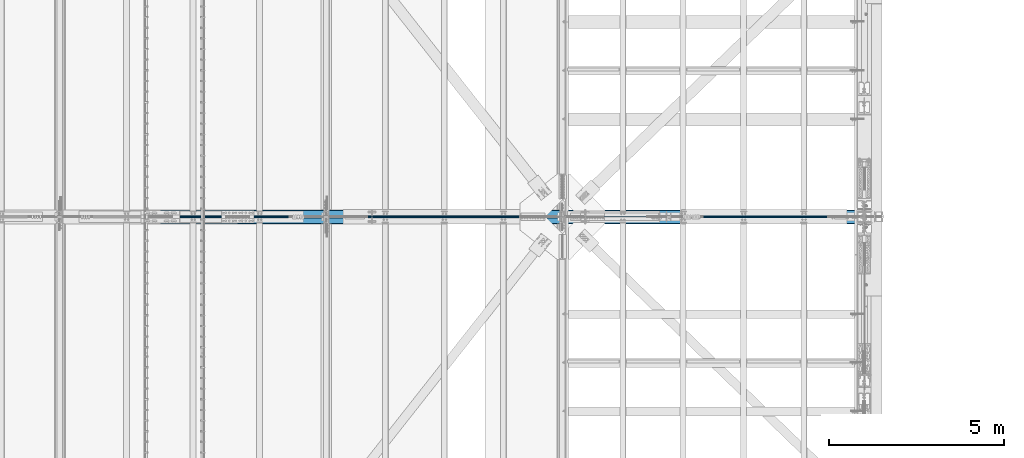
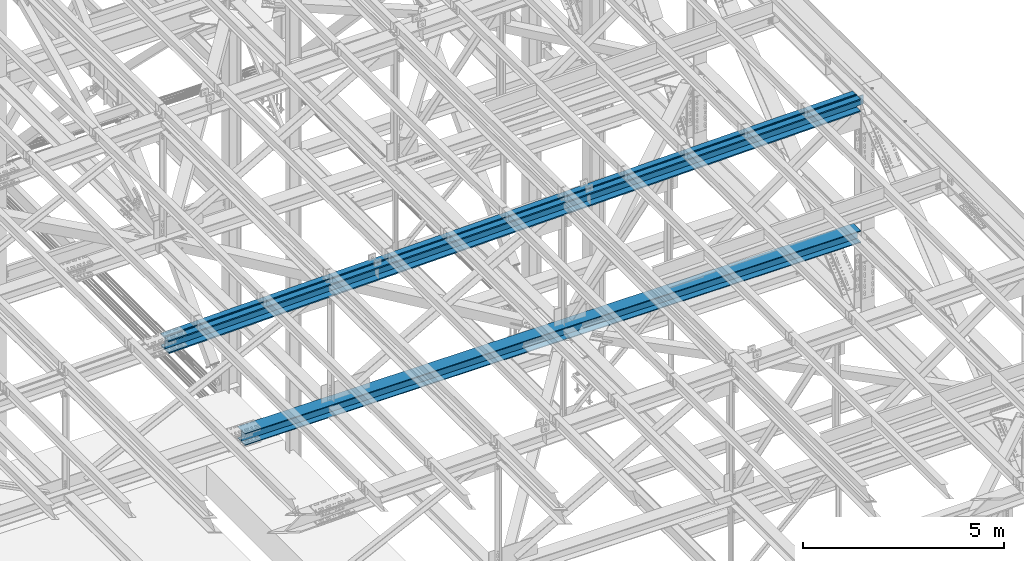
# One storey, part 1906 of 3843: 3 beams, 3 elements without a shape of their own.
"""IFC2X3 building model written with IfcOpenShell, lengths in millimetres."""

from ifc_helpers import new_model, si_unit, frame, origin_with_axes, place, context, subcontext, project, spatial, faceted_brep, material, type_object, element, aggregate, save


model = new_model("IFC2X3")

# Units and contexts
model_context = context("Model", 3, precision=1e-05, world=origin_with_axes())
body_context = subcontext(model_context, "Body", "Model", "MODEL_VIEW")
ifc_project = project(units=[si_unit("LENGTHUNIT", "METRE", prefix="MILLI"), si_unit("AREAUNIT", "SQUARE_METRE"), si_unit("VOLUMEUNIT", "CUBIC_METRE"), si_unit("MASSUNIT", "GRAM", prefix="KILO"), si_unit("TIMEUNIT", "SECOND"), si_unit("PLANEANGLEUNIT", "RADIAN"), si_unit("SOLIDANGLEUNIT", "STERADIAN"), si_unit("THERMODYNAMICTEMPERATUREUNIT", "DEGREE_CELSIUS"), si_unit("LUMINOUSINTENSITYUNIT", "LUMEN")], contexts=[model_context])

# Site, building, storey
site_placement = place(None, origin_with_axes())
site = spatial("IfcSite", under=ifc_project, at=site_placement, CompositionType="ELEMENT")
building_placement = place(site_placement, origin_with_axes())
building = spatial("IfcBuilding", under=site, at=building_placement, Name="Undefined", CompositionType="ELEMENT")
storey_placement = place(building_placement, origin_with_axes())
storey = spatial("IfcBuildingStorey", under=building, at=storey_placement, Name="Undefined", CompositionType="ELEMENT", Elevation=0.0)

# Assembly, beam
assembly_1_placement = place(storey_placement, origin_with_axes())
assembly_1 = element("IfcElementAssembly", 1, at=assembly_1_placement, inside=storey, Name="dummy", AssemblyPlace="NOTDEFINED", PredefinedType="RIGID_FRAME")
ifc_material = material(Name="STEEL/A992")
beam_type_1 = type_object("IfcBeamType", PredefinedType="NOTDEFINED")
beam_1_placement = place(assembly_1_placement, frame((65512.9690554867, 75628.5, 46111.090973795), z_axis=(-0.019790410992835, 0.0, 0.999804150637881), x_axis=(0.999804150637881, 0.0, 0.019790410992832)))
beam_1 = element("IfcBeam", 2, at=beam_1_placement, type_object=beam_type_1, material=ifc_material, Name="dummy", context=body_context, shape_type="Brep", body=[
    faceted_brep([(0.0, -24.6059999999998, 0.0), (0.0, -21.3094210855197, -12.3029999999999), (19921.5396437136, -21.3094210855197, -12.3029999482751), (19921.5396437135, -24.6059999999998, 5.17538865096867e-08), (0.0, -12.3029999999999, -21.3094210855197), (19921.5396437136, -12.3029999999999, -21.309421033824), (0.0, 0.0, -24.6059999999998), (19921.5396437136, 0.0, -24.6059999483186), (0.0, 12.3029999999999, -21.3094210855197), (19921.5396437136, 12.3029999999999, -21.309421033824), (0.0, 21.3094210855197, -12.3029999999999), (19921.5396437136, 21.3094210855197, -12.3029999482751), (0.0, 24.6059999999998, 0.0), (19921.5396437135, 24.6059999999998, 5.17538865096867e-08), (0.0, 21.3094210855197, 12.3029999999999), (19921.5396437135, 21.3094210855197, 12.3030000517901), (0.0, 12.3029999999999, 21.3094210855197), (19921.5396437135, 12.3029999999999, 21.3094211373318), (0.0, 0.0, 24.6059999999998), (19921.5396437135, 0.0, 24.6060000518191), (0.0, -12.3029999999999, 21.3094210855197), (19921.5396437135, -12.3029999999999, 21.3094211373318), (0.0, -21.3094210855197, 12.3029999999999), (19921.5396437135, -21.3094210855197, 12.3030000517901)], [[[0, 1, 2, 3]], [[1, 4, 5, 2]], [[4, 6, 7, 5]], [[6, 8, 9, 7]], [[8, 10, 11, 9]], [[10, 12, 13, 11]], [[12, 14, 15, 13]], [[14, 16, 17, 15]], [[16, 18, 19, 17]], [[18, 20, 21, 19]], [[20, 22, 23, 21]], [[22, 0, 3, 23]], [[5, 7, 9, 11, 13, 15, 17, 19, 21, 23, 3, 2]], [[22, 20, 18, 16, 14, 12, 10, 8, 6, 4, 1, 0]]]),
])
aggregate(assembly_1, [beam_1])

assembly_2_placement = place(storey_placement, origin_with_axes())
assembly_2 = element("IfcElementAssembly", 3, at=assembly_2_placement, inside=storey, Name="BEAM", AssemblyPlace="NOTDEFINED", PredefinedType="RIGID_FRAME")
beam_type_2 = type_object("IfcBeamType", Name="W14X193", PredefinedType="NOTDEFINED")
beam_2_placement = place(assembly_2_placement, frame((65510.8293646569, 75628.5, 45914.1524515103), z_axis=(-0.0197786729982909, 0.0, 0.999804382914191), x_axis=(0.999804380738174, 0.0, 0.0197787829948203)))
beam_2 = element("IfcBeam", 4, at=beam_2_placement, type_object=beam_type_2, material=ifc_material, Name="BEAM", ObjectType="W14X193", context=body_context, shape_type="Brep", body=[
    faceted_brep([(19920.5612871761, -11.1125000000029, -159.992412711617), (19920.5612871761, -200.025000000001, -159.992412711617), (19920.499121162, -200.025000000001, -196.504859770212), (19920.499121162, 200.025000000001, -196.504859770212), (19920.5612871761, 200.025000000001, -159.992412711617), (19920.5612871761, 11.1125000000029, -159.992412711617), (19920.5748656065, 11.1125000000029, -152.017287854047), (19920.5748656065, -11.1125000000029, -152.017287854047), (19921.5498688769, 11.1125000000029, -147.158861330223), (19921.5498688769, -11.1125000000029, -147.158861330223), (19924.3098937806, 11.1125000000029, -143.043378102717), (19924.3098937806, -11.1125000000029, -143.043378102717), (19928.4347515457, 11.1125000000029, -140.297383185971), (19928.4347515457, -11.1125000000029, -140.297383185971), (19933.2964699694, 11.1125000000029, -139.338929413556), (19933.2964699694, -11.1125000000029, -139.338929413556), (20111.3615741998, -11.1125000000029, -139.642102676553), (20111.3615741998, 11.1125000000029, -139.642102676553), (16116.5786885021, 200.025000000001, 202.348008926172), (16116.5786885021, -200.025000000001, 202.348008926172), (18131.1922933243, -200.025000000001, 199.942504537845), (18131.1922933243, 200.025000000001, 199.942504537845), (14101.9643802748, 200.025000000001, 204.066226545852), (14101.9643802748, -200.025000000001, 204.066226545852), (12087.3496031107, 200.025000000001, 205.097157195742), (12087.3496031107, -200.025000000001, 205.097157195742), (10072.7345914782, 200.025000000001, 205.440800756616), (10072.7345914782, -200.025000000001, 205.440800756616), (8058.1195798456, 200.025000000001, 205.097157188429), (8058.1195798456, -200.025000000001, 205.097157188429), (6043.50480268151, 200.025000000001, 204.066226531235), (6043.50480268151, -200.025000000001, 204.066226531235), (4028.89049445419, 200.025000000001, 202.348008904228), (4028.89049445419, -200.025000000001, 202.348008904228), (2014.27688963198, 200.025000000001, 199.942504508603), (2014.27688963198, -200.025000000001, 199.942504508603), (6.0142170227482, 200.025000000001, 196.859462000226), (6.0142170227482, -200.025000000001, 196.859462000226), (18131.1424682946, 11.1125000000029, 163.430038533632), (18131.1424682946, 200.025000000001, 163.430038533632), (19927.4572595197, 200.025000000001, 160.67237395011), (19927.4572595197, 11.1125000000029, 160.67237395011), (16116.5413197247, 11.1125000000029, 165.835528048839), (16116.5413197247, 200.025000000001, 165.835528048839), (14101.9394677542, 11.1125000000029, 167.553735044879), (14101.9394677542, 200.025000000001, 167.553735044879), (12087.3371468497, 11.1125000000029, 168.584659320572), (12087.3371468497, 200.025000000001, 168.584659320572), (10072.7345914782, 11.1125000000029, 168.928300756721), (10072.7345914782, 200.025000000001, 168.928300756721), (8058.13203610678, 11.1125000000029, 168.584659313266), (8058.13203610678, 200.025000000001, 168.584659313266), (6043.52971520228, 11.1125000000029, 167.553735030247), (6043.52971520228, 200.025000000001, 167.553735030247), (4028.92786323171, 11.1125000000029, 165.835528026902), (4028.92786323171, 200.025000000001, 165.835528026902), (2014.3267146619, 11.1125000000029, 163.430038504383), (2014.3267146619, 200.025000000001, 163.430038504383), (6.07649798043713, 11.1125000000029, 160.347015118088), (6.07649798043713, 200.025000000001, 160.347015118088), (16116.2131243754, 200.025000000001, -154.839304004214), (16116.2131243754, 11.1125000000029, -154.839304004214), (18130.7048745547, 11.1125000000029, -157.244662894722), (18130.7048745547, 200.025000000001, -157.244662894722), (14101.7206708336, 200.025000000001, -153.121190311555), (14101.7206708336, 11.1125000000029, -153.121190311555), (12087.2277483833, 200.025000000001, -152.090322017881), (12087.2277483833, 11.1125000000029, -152.090322017881), (10072.7345914788, 200.025000000001, -151.746699242423), (10072.7345914788, 11.1125000000029, -151.746699242423), (8058.2414345743, 200.025000000001, -152.0903220252), (8058.2414345743, 11.1125000000029, -152.0903220252), (6043.74851212402, 200.025000000001, -153.121190326179), (6043.74851212402, 11.1125000000029, -153.121190326179), (4029.25605858218, 200.025000000001, -154.839304026151), (4029.25605858218, 11.1125000000029, -154.839304026151), (2014.76430840291, 200.025000000001, -157.244662923971), (2014.76430840291, 11.1125000000029, -157.244662923971), (6.62348726096388, 200.025000000001, -160.327518368547), (6.62348726096388, 11.1125000000029, -160.327518368547), (16116.175755598, -200.025000000001, -191.351784881546), (16116.175755598, 200.025000000001, -191.351784881546), (18130.6550495249, 200.025000000001, -193.757128898935), (18130.6550495249, -200.025000000001, -193.757128898935), (14101.6957583129, -200.025000000001, -189.633681812535), (14101.6957583129, 200.025000000001, -189.633681812535), (12087.2152921223, -200.025000000001, -188.602819893051), (12087.2152921223, 200.025000000001, -188.602819893051), (10072.7345914789, -200.025000000001, -188.259199242319), (10072.7345914789, 200.025000000001, -188.259199242319), (8058.25389083543, -200.025000000001, -188.60281990037), (8058.25389083543, 200.025000000001, -188.60281990037), (6043.77342464479, -200.025000000001, -189.633681827167), (6043.77342464479, 200.025000000001, -189.633681827167), (4029.29342735971, -200.025000000001, -191.351784903483), (4029.29342735971, 200.025000000001, -191.351784903483), (2014.81413343282, -200.025000000001, -193.757128928191), (2014.81413343282, 200.025000000001, -193.757128928191), (6.68576821865281, -200.025000000001, -196.839965250685), (6.68576821865281, 200.025000000001, -196.839965250685), (16116.2131243754, -11.1125000000029, -154.839304004214), (16116.2131243754, -200.025000000001, -154.839304004214), (18130.7048745547, -200.025000000001, -157.244662894722), (18130.7048745547, -11.1125000000029, -157.244662894722), (14101.7206708336, -11.1125000000029, -153.121190311555), (14101.7206708336, -200.025000000001, -153.121190311555), (12087.2277483833, -11.1125000000029, -152.090322017881), (12087.2277483833, -200.025000000001, -152.090322017881), (10072.7345914788, -11.1125000000029, -151.746699242423), (10072.7345914788, -200.025000000001, -151.746699242423), (8058.2414345743, -11.1125000000029, -152.0903220252), (8058.2414345743, -200.025000000001, -152.0903220252), (6043.74851212402, -11.1125000000029, -153.121190326179), (6043.74851212402, -200.025000000001, -153.121190326179), (4029.25605858218, -11.1125000000029, -154.839304026151), (4029.25605858218, -200.025000000001, -154.839304026151), (2014.76430840291, -11.1125000000029, -157.244662923971), (2014.76430840291, -200.025000000001, -157.244662923971), (6.62348726096388, -11.1125000000029, -160.327518368547), (6.62348726096388, -200.025000000001, -160.327518368547), (6.07649798043713, -11.1125000000029, 160.347015118088), (6.07649798043713, -200.025000000001, 160.347015118088), (2014.3267146619, -11.1125000000029, 163.430038504383), (2014.3267146619, -200.025000000001, 163.430038504383), (4028.92786323171, -11.1125000000029, 165.835528026902), (4028.92786323171, -200.025000000001, 165.835528026902), (6043.52971520228, -11.1125000000029, 167.553735030247), (6043.52971520228, -200.025000000001, 167.553735030247), (8058.13203610678, -11.1125000000029, 168.584659313266), (8058.13203610678, -200.025000000001, 168.584659313266), (10072.7345914782, -11.1125000000029, 168.928300756721), (10072.7345914782, -200.025000000001, 168.928300756721), (12087.3371468497, -11.1125000000029, 168.584659320572), (12087.3371468497, -200.025000000001, 168.584659320572), (14101.9394677542, -11.1125000000029, 167.553735044879), (14101.9394677542, -200.025000000001, 167.553735044879), (16116.5413197247, -11.1125000000029, 165.835528048839), (16116.5413197247, -200.025000000001, 165.835528048839), (18131.1424682946, -11.1125000000029, 163.430038533632), (18131.1424682946, -200.025000000001, 163.430038533632), (19927.4572595197, -11.1125000000029, 160.67237395011), (19927.4572595197, -200.025000000001, 160.67237395011), (19927.5194255337, -200.025000000001, 197.184821008712), (19927.5194255337, 200.025000000001, 197.184821008712), (19927.4438074376, -11.1125000000029, 152.771458501105), (19927.4438074376, 11.1125000000029, 152.771458501105), (19928.40226121, -11.1125000000029, 147.90974007747), (19928.40226121, 11.1125000000029, 147.90974007747), (19931.1482561267, -11.1125000000029, 143.784882312415), (19931.1482561267, 11.1125000000029, 143.784882312415), (19935.2637393542, -11.1125000000029, 141.024857408775), (19935.2637393542, 11.1125000000029, 141.024857408775), (19940.1221658781, -11.1125000000029, 140.049854138422), (19940.1221658781, 11.1125000000029, 140.049854138422), (20116.8886692579, -11.1125000000029, 139.748891867705), (20116.8886692579, 11.1125000000029, 139.748891867705)], [[[0, 1, 2, 3, 4, 5, 6, 7]], [[7, 6, 8, 9]], [[9, 8, 10, 11]], [[11, 10, 12, 13]], [[13, 12, 14, 15]], [[16, 15, 14, 17]], [[18, 19, 20, 21]], [[22, 23, 19, 18]], [[24, 25, 23, 22]], [[26, 27, 25, 24]], [[28, 29, 27, 26]], [[30, 31, 29, 28]], [[32, 33, 31, 30]], [[34, 35, 33, 32]], [[35, 34, 36, 37]], [[38, 39, 40, 41]], [[42, 43, 39, 38]], [[44, 45, 43, 42]], [[46, 47, 45, 44]], [[48, 49, 47, 46]], [[50, 51, 49, 48]], [[52, 53, 51, 50]], [[54, 55, 53, 52]], [[56, 57, 55, 54]], [[57, 56, 58, 59]], [[60, 61, 62, 63]], [[64, 65, 61, 60]], [[66, 67, 65, 64]], [[68, 69, 67, 66]], [[70, 71, 69, 68]], [[72, 73, 71, 70]], [[74, 75, 73, 72]], [[76, 77, 75, 74]], [[77, 76, 78, 79]], [[80, 81, 82, 83]], [[84, 85, 81, 80]], [[86, 87, 85, 84]], [[88, 89, 87, 86]], [[90, 91, 89, 88]], [[92, 93, 91, 90]], [[94, 95, 93, 92]], [[96, 97, 95, 94]], [[97, 96, 98, 99]], [[100, 101, 102, 103]], [[104, 105, 101, 100]], [[106, 107, 105, 104]], [[108, 109, 107, 106]], [[110, 111, 109, 108]], [[112, 113, 111, 110]], [[114, 115, 113, 112]], [[116, 117, 115, 114]], [[117, 116, 118, 119]], [[120, 121, 37, 36, 59, 58, 79, 78, 99, 98, 119, 118]], [[122, 123, 121, 120]], [[123, 122, 124, 125]], [[125, 124, 126, 127]], [[127, 126, 128, 129]], [[129, 128, 130, 131]], [[131, 130, 132, 133]], [[133, 132, 134, 135]], [[135, 134, 136, 137]], [[137, 136, 138, 139]], [[139, 138, 140, 141]], [[20, 19, 23, 25, 27, 29, 31, 33, 35, 37, 121, 123, 125, 127, 129, 131, 133, 135, 137, 139, 141, 142]], [[21, 20, 142, 143]], [[39, 43, 45, 47, 49, 51, 53, 55, 57, 59, 36, 34, 32, 30, 28, 26, 24, 22, 18, 21, 143, 40]], [[142, 141, 140, 144, 145, 41, 40, 143]], [[146, 147, 145, 144]], [[148, 149, 147, 146]], [[150, 151, 149, 148]], [[152, 153, 151, 150]], [[154, 155, 153, 152]], [[155, 154, 16, 17]], [[12, 10, 8, 6, 5, 62, 61, 65, 67, 69, 71, 73, 75, 77, 79, 58, 56, 54, 52, 50, 48, 46, 44, 42, 38, 41, 145, 147, 149, 151, 153, 155, 17, 14]], [[63, 62, 5, 4]], [[82, 81, 85, 87, 89, 91, 93, 95, 97, 99, 78, 76, 74, 72, 70, 68, 66, 64, 60, 63, 4, 3]], [[83, 82, 3, 2]], [[102, 101, 105, 107, 109, 111, 113, 115, 117, 119, 98, 96, 94, 92, 90, 88, 86, 84, 80, 83, 2, 1]], [[103, 102, 1, 0]], [[154, 152, 150, 148, 146, 144, 140, 138, 136, 134, 132, 130, 128, 126, 124, 122, 120, 118, 116, 114, 112, 110, 108, 106, 104, 100, 103, 0, 7, 9, 11, 13, 15, 16]]]),
])
aggregate(assembly_2, [beam_2])

assembly_3_placement = place(storey_placement, origin_with_axes())
assembly_3 = element("IfcElementAssembly", 5, at=assembly_3_placement, inside=storey, Name="BEAM", AssemblyPlace="NOTDEFINED", PredefinedType="RIGID_FRAME")
beam_type_3 = type_object("IfcBeamType", Name="W14X120", PredefinedType="NOTDEFINED")
beam_3_placement = place(assembly_3_placement, frame((67716.3999101935, 75628.5, 42327.3896933045), z_axis=(0.00156029399958788, 0.0, 0.999998782740577), x_axis=(0.999998782740577, 0.0, -0.00156029399959503)))
beam_3 = element("IfcBeam", 6, at=beam_3_placement, type_object=beam_type_3, material=ifc_material, Name="BEAM", ObjectType="W14X120", context=body_context, shape_type="Brep", body=[
    faceted_brep([(3586.33715640679, -185.737500000003, 164.695732342392), (3586.33715640679, -7.14375000000291, 164.695732342392), (5379.62833851376, -7.14375000000291, 166.057737976429), (5379.62833851376, -185.737500000003, 166.057737976429), (1793.04647083281, -185.737500000003, 162.788924631706), (1793.04647083281, -7.14375000000291, 162.788924631706), (6.10644042312924, -185.737500000003, 160.345996106429), (6.10644042312924, -7.14375000000291, 160.345996106429), (14346.1076068797, 185.737500000003, 188.508222468998), (14346.1076068797, -185.737500000003, 188.508222468998), (16139.4055266909, -185.737500000003, 186.601407071656), (16139.4055266909, 185.737500000003, 186.601407071656), (12552.8091905336, 185.737500000003, 189.870233591901), (12552.8091905336, -185.737500000003, 189.870233591901), (10759.510443164, 185.737500000003, 190.687440313719), (10759.510443164, -185.737500000003, 190.687440313719), (8966.21153028277, 185.737500000003, 190.959842561795), (8966.21153028277, -185.737500000003, 190.959842561795), (7172.91261740155, 185.737500000003, 190.687440308189), (7172.91261740155, -185.737500000003, 190.687440308189), (5379.61387003202, 185.737500000003, 189.870233580856), (5379.61387003202, -185.737500000003, 189.870233580856), (3586.31545368583, 185.737500000003, 188.508222452416), (3586.31545368583, -185.737500000003, 188.508222452416), (1793.01753387471, 185.737500000003, 186.601407049558), (1793.01753387471, -185.737500000003, 186.601407049558), (6.07026913922164, 185.737500000003, 184.158468634232), (6.07026913922164, -185.737500000003, 184.158468634232), (14346.0859041589, 7.14375000000291, 164.695732358974), (14346.0859041589, 185.737500000003, 164.695732358974), (16139.3765897328, 185.737500000003, 162.788924653803), (16139.3765897328, 7.14375000000291, 162.788924653803), (12552.7947220519, 7.14375000000291, 166.057737987474), (12552.7947220519, 185.737500000003, 166.057737987474), (10759.5032089229, 7.14375000000291, 166.874941412643), (10759.5032089229, 185.737500000003, 166.874941412643), (8966.21153028282, 7.14375000000291, 167.147342561839), (8966.21153028282, 185.737500000003, 167.147342561839), (7172.91985164279, 7.14375000000291, 166.874941407121), (7172.91985164279, 185.737500000003, 166.874941407121), (5379.62833851376, 7.14375000000291, 166.057737976429), (5379.62833851376, 185.737500000003, 166.057737976429), (3586.33715640679, 7.14375000000291, 164.695732342392), (3586.33715640679, 185.737500000003, 164.695732342392), (1793.04647083281, 7.14375000000291, 162.788924631706), (1793.04647083281, 185.737500000003, 162.788924631706), (6.10644042312924, 7.14375000000291, 160.345996106429), (6.10644042312924, 185.737500000003, 160.345996106429), (14345.7936408511, 185.737500000003, -155.979134455978), (14345.7936408511, 7.14375000000291, -155.979134455978), (16138.9869053642, 7.14375000000291, -157.885838573238), (16138.9869053642, 185.737500000003, -157.885838573238), (12552.5998798319, 185.737500000003, -154.617202818838), (12552.5998798319, 7.14375000000291, -154.617202818838), (10759.4057878086, 185.737500000003, -153.800043788498), (10759.4057878086, 7.14375000000291, -153.800043788498), (8966.21153028331, 185.737500000003, -153.527657437575), (8966.21153028331, 7.14375000000291, -153.527657437575), (7173.01727275802, 185.737500000003, -153.800043794021), (7173.01727275802, 7.14375000000291, -153.800043794021), (5379.82318073475, 185.737500000003, -154.617202829897), (5379.82318073475, 7.14375000000291, -154.617202829897), (3586.62941971555, 185.737500000003, -155.979134472553), (3586.62941971555, 7.14375000000291, -155.979134472553), (1793.43615520238, 185.737500000003, -157.885838595343), (1793.43615520238, 7.14375000000291, -157.885838595343), (6.59354704637371, 185.737500000003, -160.328633934761), (6.59354704637371, 7.14375000000291, -160.328633934761), (14345.7719381302, -185.737500000003, -179.791624565994), (14345.7719381302, 185.737500000003, -179.791624565994), (16138.9579684062, 185.737500000003, -181.698320991083), (16138.9579684062, -185.737500000003, -181.698320991083), (12552.5854113502, -185.737500000003, -178.429698423279), (12552.5854113502, 185.737500000003, -178.429698423279), (10759.3985535674, -185.737500000003, -177.612542689574), (10759.3985535674, 185.737500000003, -177.612542689574), (8966.21153028334, -185.737500000003, -177.340157437538), (8966.21153028334, 185.737500000003, -177.340157437538), (7173.02450699924, -185.737500000003, -177.612542695089), (7173.02450699924, 185.737500000003, -177.612542695089), (5379.83764921651, -185.737500000003, -178.429698434324), (5379.83764921651, 185.737500000003, -178.429698434324), (3586.65112243649, -185.737500000003, -179.791624582569), (3586.65112243649, 185.737500000003, -179.791624582569), (1793.46509216051, -185.737500000003, -181.698321013188), (1793.46509216051, 185.737500000003, -181.698321013188), (6.62971833028132, -185.737500000003, -184.141106462579), (6.62971833028132, 185.737500000003, -184.141106462579), (6.59354704637371, -185.737500000003, -160.328633934761), (6.59354704637371, -7.14375000000291, -160.328633934761), (1793.43615520238, -185.737500000003, -157.885838595343), (1793.43615520238, -7.14375000000291, -157.885838595343), (3586.62941971555, -185.737500000003, -155.979134472553), (3586.62941971555, -7.14375000000291, -155.979134472553), (5379.82318073475, -185.737500000003, -154.617202829897), (5379.82318073475, -7.14375000000291, -154.617202829897), (7173.01727275802, -185.737500000003, -153.800043794021), (7173.01727275802, -7.14375000000291, -153.800043794021), (8966.21153028331, -185.737500000003, -153.527657437575), (8966.21153028331, -7.14375000000291, -153.527657437575), (10759.4057878086, -185.737500000003, -153.800043788498), (10759.4057878086, -7.14375000000291, -153.800043788498), (12552.5998798319, -185.737500000003, -154.617202818838), (12552.5998798319, -7.14375000000291, -154.617202818838), (14345.7936408511, -185.737500000003, -155.979134455978), (14345.7936408511, -7.14375000000291, -155.979134455978), (16138.9869053642, -185.737500000003, -157.885838573238), (16138.9869053642, -7.14375000000291, -157.885838573238), (17732.6464561593, -7.14375000000291, -160.064533045617), (17732.6464561593, -185.737500000003, -160.064533045617), (17732.6464561593, -147.63754057177, -160.064533045617), (16139.3765897328, -7.14375000000291, 162.788924653803), (14346.0859041589, -7.14375000000291, 164.695732358974), (12552.7947220519, -7.14375000000291, 166.057737987474), (10759.5032089229, -7.14375000000291, 166.874941412643), (8966.21153028282, -7.14375000000291, 167.147342561839), (7172.91985164279, -7.14375000000291, 166.874941407121), (17732.1460470964, -7.14375000000291, 160.611447029558), (7172.91985164279, -185.737500000003, 166.874941407121), (8966.21153028282, -185.737500000003, 167.147342561839), (10759.5032089229, -185.737500000003, 166.874941412643), (12552.7947220519, -185.737500000003, 166.057737987474), (14346.0859041589, -185.737500000003, 164.695732358974), (16139.3765897328, -185.737500000003, 162.788924653803), (17732.1460470964, -185.737500000003, 160.611447029558), (17732.1088880076, -185.737500000003, 184.424019807411), (17732.1088880076, 147.637446534121, 184.424019807411), (17732.1088880076, 185.737500000003, 184.424019807411), (17732.1088880076, -147.63754057177, 184.424019807411), (17732.1460470964, 185.737500000003, 160.611447029558), (17732.1460470964, 7.14375000000291, 160.611447029558), (17732.1460470964, 147.637446534121, 160.611447029558), (17732.5855231323, 7.14375000000291, -121.016962597096), (17732.6464561593, 7.14375000000291, -160.064533045617), (17732.2066697978, 7.14375000000291, 121.762741805302), (17732.6464561593, 185.737500000003, -160.064533045617), (17732.6464561593, 147.637446534121, -160.064533045617), (17732.6836152481, 185.737500000003, -183.877105823478), (17732.6836152481, -147.63754057177, -183.877105823478), (17732.6836152481, -185.737500000003, -183.877105823478), (17732.6836152481, 147.637446534121, -183.877105823478), (17732.1460470964, -147.63754057177, 160.611447029558)], [[[0, 1, 2, 3]], [[4, 5, 1, 0]], [[5, 4, 6, 7]], [[8, 9, 10, 11]], [[12, 13, 9, 8]], [[14, 15, 13, 12]], [[16, 17, 15, 14]], [[18, 19, 17, 16]], [[20, 21, 19, 18]], [[22, 23, 21, 20]], [[24, 25, 23, 22]], [[25, 24, 26, 27]], [[28, 29, 30, 31]], [[32, 33, 29, 28]], [[34, 35, 33, 32]], [[36, 37, 35, 34]], [[38, 39, 37, 36]], [[40, 41, 39, 38]], [[42, 43, 41, 40]], [[44, 45, 43, 42]], [[45, 44, 46, 47]], [[48, 49, 50, 51]], [[52, 53, 49, 48]], [[54, 55, 53, 52]], [[56, 57, 55, 54]], [[58, 59, 57, 56]], [[60, 61, 59, 58]], [[62, 63, 61, 60]], [[64, 65, 63, 62]], [[65, 64, 66, 67]], [[68, 69, 70, 71]], [[72, 73, 69, 68]], [[74, 75, 73, 72]], [[76, 77, 75, 74]], [[78, 79, 77, 76]], [[80, 81, 79, 78]], [[82, 83, 81, 80]], [[84, 85, 83, 82]], [[85, 84, 86, 87]], [[7, 6, 27, 26, 47, 46, 67, 66, 87, 86, 88, 89]], [[90, 91, 89, 88]], [[91, 90, 92, 93]], [[93, 92, 94, 95]], [[95, 94, 96, 97]], [[97, 96, 98, 99]], [[99, 98, 100, 101]], [[101, 100, 102, 103]], [[103, 102, 104, 105]], [[105, 104, 106, 107]], [[108, 107, 106, 109, 110]], [[111, 112, 113, 114, 115, 116, 2, 1, 5, 7, 89, 91, 93, 95, 97, 99, 101, 103, 105, 107, 108, 117]], [[3, 2, 116, 118]], [[10, 9, 13, 15, 17, 19, 21, 23, 25, 27, 6, 4, 0, 3, 118, 119, 120, 121, 122, 123, 124, 125]], [[126, 127, 11, 10, 125, 128]], [[30, 29, 33, 35, 37, 39, 41, 43, 45, 47, 26, 24, 22, 20, 18, 16, 14, 12, 8, 11, 127, 129]], [[130, 31, 30, 129, 131]], [[132, 133, 50, 49, 53, 55, 57, 59, 61, 63, 65, 67, 46, 44, 42, 40, 38, 36, 34, 32, 28, 31, 130, 134]], [[135, 51, 50, 133, 136]], [[70, 69, 73, 75, 77, 79, 81, 83, 85, 87, 66, 64, 62, 60, 58, 56, 54, 52, 48, 51, 135, 137]], [[138, 139, 71, 70, 137, 140]], [[106, 104, 102, 100, 98, 96, 94, 92, 90, 88, 86, 84, 82, 80, 78, 76, 74, 72, 68, 71, 139, 109]], [[138, 140, 137, 135, 136, 133, 132, 134, 130, 131, 129, 127, 126, 128, 125, 124, 141, 117, 108, 110, 109, 139]], [[124, 123, 111, 117, 141]], [[122, 112, 111, 123]], [[121, 113, 112, 122]], [[120, 114, 113, 121]], [[119, 115, 114, 120]], [[118, 116, 115, 119]]]),
])
aggregate(assembly_3, [beam_3])

save(model, "model.ifc")
